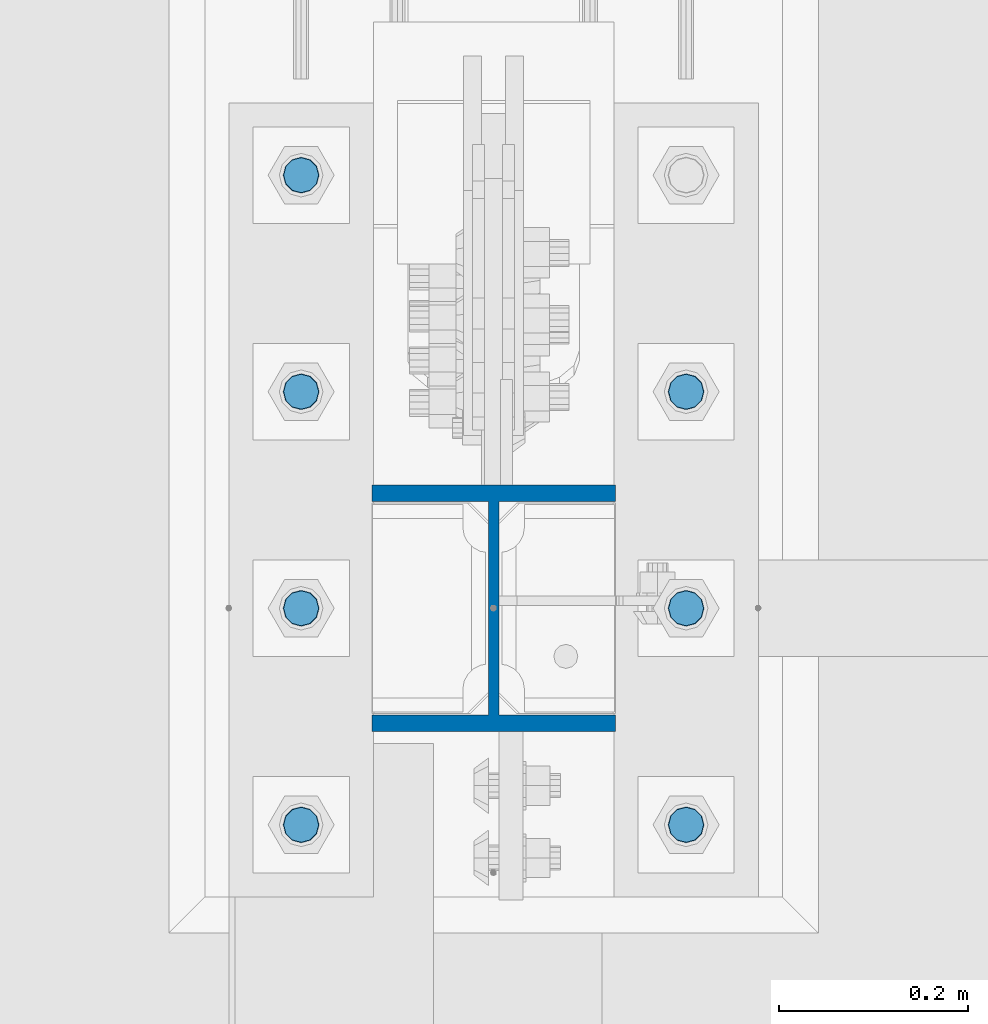
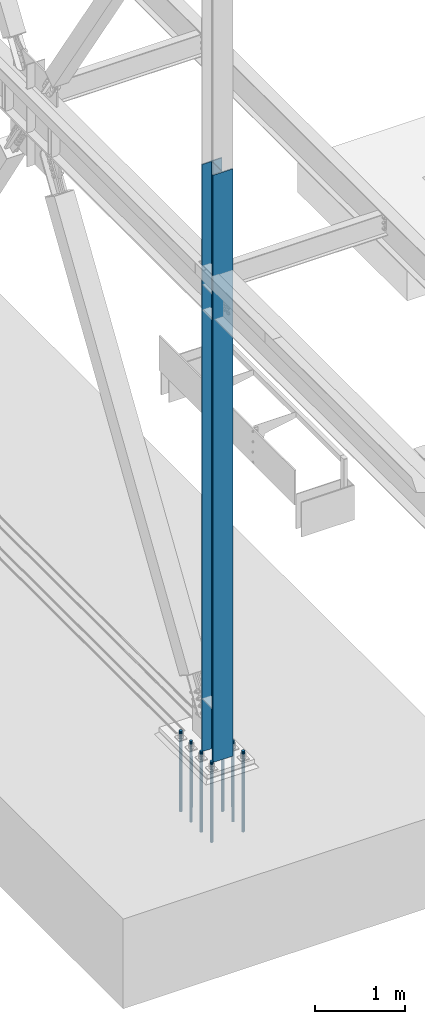
# One storey, part 1346 of 3843: 8 columns, 2 elements without a shape of their own.
"""IFC2X3 building model written with IfcOpenShell, lengths in millimetres."""

from ifc_helpers import new_model, si_unit, frame, origin_with_axes, place, context, subcontext, project, spatial, faceted_brep, material, type_object, element, aggregate, save


model = new_model("IFC2X3")

# Units and contexts
model_context = context("Model", 3, precision=1e-05, world=origin_with_axes())
body_context = subcontext(model_context, "Body", "Model", "MODEL_VIEW")
ifc_project = project(units=[si_unit("LENGTHUNIT", "METRE", prefix="MILLI"), si_unit("AREAUNIT", "SQUARE_METRE"), si_unit("VOLUMEUNIT", "CUBIC_METRE"), si_unit("MASSUNIT", "GRAM", prefix="KILO"), si_unit("TIMEUNIT", "SECOND"), si_unit("PLANEANGLEUNIT", "RADIAN"), si_unit("SOLIDANGLEUNIT", "STERADIAN"), si_unit("THERMODYNAMICTEMPERATUREUNIT", "DEGREE_CELSIUS"), si_unit("LUMINOUSINTENSITYUNIT", "LUMEN")], contexts=[model_context])

# Site, building, storey
site_placement = place(None, origin_with_axes())
site = spatial("IfcSite", under=ifc_project, at=site_placement, CompositionType="ELEMENT")
building_placement = place(site_placement, origin_with_axes())
building = spatial("IfcBuilding", under=site, at=building_placement, Name="Undefined", CompositionType="ELEMENT")
storey_placement = place(building_placement, origin_with_axes())
storey = spatial("IfcBuildingStorey", under=building, at=storey_placement, Name="Undefined", CompositionType="ELEMENT", Elevation=0.0)

# Assembly, column
assembly_1_placement = place(storey_placement, origin_with_axes())
assembly_1 = element("IfcElementAssembly", 1, at=assembly_1_placement, inside=storey, Name="COLUMN", AssemblyPlace="NOTDEFINED", PredefinedType="RIGID_FRAME")
ifc_material_1 = material(Name="STEEL/A992")
column_type_1 = type_object("IfcColumnType", Name="W10X60", PredefinedType="NOTDEFINED")
column_1_placement = place(assembly_1_placement, frame((0.0, 96481.9, 29718.0), z_axis=(0.0, 1.0, 0.0), x_axis=(0.0, 0.0, 1.0)))
column_1 = element("IfcColumn", 2, at=column_1_placement, type_object=column_type_1, material=ifc_material_1, Name="COLUMN", ObjectType="W10X60", context=body_context, shape_type="Brep", body=[
    faceted_brep([(101.599999999999, 128.587499999994, -130.174999999999), (101.599999999999, 128.587499999994, -112.712500000001), (8077.2, 128.5875, -112.712499999994), (8077.2, 128.5875, -130.175000000003), (101.599999999999, 5.55624999999418, -112.712500000001), (8077.2, 5.55625, -112.712499999994), (101.599999999999, 5.55624999999418, 112.712500000001), (8077.2, 5.55625, 112.712499999994), (101.599999999999, 128.587499999994, 112.712500000001), (8077.2, 128.5875, 112.712499999994), (101.599999999999, 128.587499999994, 130.174999999999), (8077.2, 128.5875, 130.175000000003), (101.599999999999, -128.587499999994, 130.174999999999), (8077.2, -128.5875, 130.175000000003), (101.599999999999, -128.587499999994, 112.712500000001), (8077.2, -128.5875, 112.712499999994), (101.599999999999, -5.55624999999418, 112.712500000001), (8077.2, -5.55625, 112.712499999994), (101.599999999999, -5.55624999999418, -112.712500000001), (8077.2, -5.55625, -112.712499999994), (101.599999999999, -128.587499999994, -112.712500000001), (8077.2, -128.5875, -112.712499999994), (101.599999999999, -128.587499999994, -130.174999999999), (8077.2, -128.5875, -130.175000000003)], [[[0, 1, 2, 3]], [[1, 4, 5, 2]], [[4, 6, 7, 5]], [[6, 8, 9, 7]], [[8, 10, 11, 9]], [[10, 12, 13, 11]], [[12, 14, 15, 13]], [[14, 16, 17, 15]], [[16, 18, 19, 17]], [[18, 20, 21, 19]], [[20, 22, 23, 21]], [[22, 0, 3, 23]], [[5, 7, 9, 11, 13, 15, 17, 19, 21, 23, 3, 2]], [[22, 20, 18, 16, 14, 12, 10, 8, 6, 4, 1, 0]]]),
])
aggregate(assembly_1, [column_1])

# Assembly, columns
assembly_2_placement = place(storey_placement, origin_with_axes())
assembly_2 = element("IfcElementAssembly", 3, at=assembly_2_placement, inside=storey, Name="TEMPLATE", AssemblyPlace="NOTDEFINED", PredefinedType="RIGID_FRAME")
ifc_material_2 = material(Name="Undefined/F1554-GR.55")
column_type_2 = type_object("IfcColumnType", PredefinedType="NOTDEFINED")
column_2_placement = place(assembly_2_placement, frame((-203.2, 96253.3, 29718.0), z_axis=(0.0, -1.0, 0.0), x_axis=(0.0, 0.0, -1.0)))
column_2 = element("IfcColumn", 4, at=column_2_placement, type_object=column_type_2, material=ifc_material_2, Name="ANCHOR_ROD", context=body_context, shape_type="Brep", body=[
    faceted_brep([(-209.549999999999, -16.0214699700155, 9.25), (-209.549999999999, -9.25, 16.0214699700118), (-209.549999999999, 0.0, 18.5), (-209.549999999999, 9.25, 16.0214699700118), (-209.549999999999, 16.0214699700155, 9.25), (-209.549999999999, 18.5, 0.0), (-209.549999999999, 16.0214699700155, -9.25), (-209.549999999999, 9.25, -16.0214699700118), (-209.549999999999, 0.0, -18.5), (-209.549999999999, -9.25, -16.0214699700118), (-209.549999999999, -16.0214699700155, -9.25), (-209.549999999999, -18.5, 0.0), (0.0, 18.5, 0.0), (0.0, 16.0214699700118, -9.25), (0.0, 9.25, -16.0214699700155), (0.0, 0.0, -18.5), (0.0, -9.25, -16.0214699700155), (0.0, -16.0214699700118, -9.25), (0.0, -18.5, 0.0), (0.0, -16.0214699700118, 9.25), (0.0, -9.25, 16.0214699700155), (0.0, 0.0, 18.5), (0.0, 9.25, 16.0214699700155), (0.0, 16.0214699700118, 9.25), (0.0, -16.4977839420972, 9.52500000000146), (0.0, -9.52500000000146, 16.4977839420972), (0.0, 0.0, 19.0499989999989), (0.0, 9.52500000000146, 16.4977839420972), (0.0, 16.4977839420972, 9.52500000000146), (0.0, 19.0500000000029, 0.0), (0.0, 16.4977839420972, -9.52500000000146), (0.0, 9.52500000000146, -16.4977839420972), (0.0, 0.0, -19.0499989999989), (0.0, -9.52500000000146, -16.4977839420972), (0.0, -16.4977839420972, -9.52500000000146), (0.0, -19.0500000000029, 0.0), (698.5, -19.0499999999993, 0.0), (698.5, -16.4977839420935, 9.52499999999418), (698.5, -9.52500000000146, 16.4977839420899), (698.5, 0.0, 19.0500000000029), (698.5, 9.52500000000146, 16.4977839420899), (698.5, 16.4977839420935, 9.52499999999418), (698.5, 19.0499999999993, 0.0), (698.5, 16.4977839420935, -9.52499999999418), (698.5, 9.52500000000146, -16.4977839420899), (698.5, 0.0, -19.0500000000029), (698.5, -9.52500000000146, -16.4977839420899), (698.5, -16.4977839420935, -9.52499999999418), (698.5, -9.25, 16.0214699700155), (698.5, 0.0, 18.5), (698.5, 9.25, 16.0214699700155), (698.5, 16.0214699700118, 9.25), (698.5, 18.5, 0.0), (698.5, 16.0214699700118, -9.25), (698.5, 9.25, -16.0214699700155), (698.5, 0.0, -18.5), (698.5, -9.25, -16.0214699700155), (698.5, -16.0214699700118, -9.25), (698.5, -18.5, 0.0), (698.5, -16.0214699700118, 9.25), (889.0, -9.25, -16.0214699700155), (889.0, 0.0, -18.5), (889.0, 9.25, -16.0214699700155), (889.0, 16.0214699700118, -9.25), (889.0, 18.5, 0.0), (889.0, 16.0214699700118, 9.25), (889.0, 9.25, 16.0214699700155), (889.0, 0.0, 18.5), (889.0, -9.25, 16.0214699700155), (889.0, -16.0214699700118, 9.25), (889.0, -18.5, 0.0), (889.0, -16.0214699700118, -9.25)], [[[0, 1, 2, 3, 4, 5, 6, 7, 8, 9, 10, 11]], [[6, 5, 12, 13]], [[7, 6, 13, 14]], [[8, 7, 14, 15]], [[9, 8, 15, 16]], [[10, 9, 16, 17]], [[11, 10, 17, 18]], [[0, 11, 18, 19]], [[1, 0, 19, 20]], [[2, 1, 20, 21]], [[3, 2, 21, 22]], [[4, 3, 22, 23]], [[5, 4, 23, 12]], [[24, 25, 26, 27, 28, 29, 30, 31, 32, 33, 34, 35], [22, 21, 20, 19, 18, 17, 16, 15, 14, 13, 12, 23]], [[24, 35, 36, 37]], [[25, 24, 37, 38]], [[26, 25, 38, 39]], [[27, 26, 39, 40]], [[28, 27, 40, 41]], [[29, 28, 41, 42]], [[30, 29, 42, 43]], [[31, 30, 43, 44]], [[32, 31, 44, 45]], [[33, 32, 45, 46]], [[34, 33, 46, 47]], [[35, 34, 47, 36]], [[46, 45, 44, 43, 42, 41, 40, 39, 38, 37, 36, 47], [48, 49, 50, 51, 52, 53, 54, 55, 56, 57, 58, 59]], [[60, 61, 62, 63, 64, 65, 66, 67, 68, 69, 70, 71]], [[68, 67, 49, 48]], [[69, 68, 48, 59]], [[70, 69, 59, 58]], [[71, 70, 58, 57]], [[60, 71, 57, 56]], [[61, 60, 56, 55]], [[62, 61, 55, 54]], [[63, 62, 54, 53]], [[64, 63, 53, 52]], [[65, 64, 52, 51]], [[66, 65, 51, 50]], [[67, 66, 50, 49]]]),
])
column_3_placement = place(assembly_2_placement, frame((203.2, 96253.3, 29718.0), z_axis=(0.0, 1.0, 0.0), x_axis=(0.0, 0.0, -1.0)))
column_3 = element("IfcColumn", 5, at=column_3_placement, type_object=column_type_2, material=ifc_material_2, Name="ANCHOR_ROD", context=body_context, shape_type="Brep", body=[
    faceted_brep([(-209.549999999999, -16.0214699700155, 9.25), (-209.549999999999, -9.25, 16.0214699700118), (-209.549999999999, 0.0, 18.5), (-209.549999999999, 9.25, 16.0214699700118), (-209.549999999999, 16.0214699700155, 9.25), (-209.549999999999, 18.5, 0.0), (-209.549999999999, 16.0214699700155, -9.25), (-209.549999999999, 9.25, -16.0214699700118), (-209.549999999999, 0.0, -18.5), (-209.549999999999, -9.25, -16.0214699700118), (-209.549999999999, -16.0214699700155, -9.25), (-209.549999999999, -18.5, 0.0), (0.0, 18.5, 0.0), (0.0, 16.0214699700118, -9.25), (0.0, 9.25, -16.0214699700155), (0.0, 0.0, -18.5), (0.0, -9.25, -16.0214699700155), (0.0, -16.0214699700118, -9.25), (0.0, -18.5, 0.0), (0.0, -16.0214699700118, 9.25), (0.0, -9.25, 16.0214699700155), (0.0, 0.0, 18.5), (0.0, 9.25, 16.0214699700155), (0.0, 16.0214699700118, 9.25), (0.0, -16.4977839420972, 9.52500000000146), (0.0, -9.52500000000146, 16.4977839420972), (0.0, 0.0, 19.0499989999989), (0.0, 9.52500000000146, 16.4977839420972), (0.0, 16.4977839420972, 9.52500000000146), (0.0, 19.0500000000029, 0.0), (0.0, 16.4977839420972, -9.52500000000146), (0.0, 9.52500000000146, -16.4977839420972), (0.0, 0.0, -19.0499989999989), (0.0, -9.52500000000146, -16.4977839420972), (0.0, -16.4977839420972, -9.52500000000146), (0.0, -19.0500000000029, 0.0), (698.5, -19.0499999999993, 0.0), (698.5, -16.4977839420935, 9.52499999999418), (698.5, -9.52500000000146, 16.4977839420899), (698.5, 0.0, 19.0500000000029), (698.5, 9.52500000000146, 16.4977839420899), (698.5, 16.4977839420935, 9.52499999999418), (698.5, 19.0499999999993, 0.0), (698.5, 16.4977839420935, -9.52499999999418), (698.5, 9.52500000000146, -16.4977839420899), (698.5, 0.0, -19.0500000000029), (698.5, -9.52500000000146, -16.4977839420899), (698.5, -16.4977839420935, -9.52499999999418), (698.5, -9.25, 16.0214699700155), (698.5, 0.0, 18.5), (698.5, 9.25, 16.0214699700155), (698.5, 16.0214699700118, 9.25), (698.5, 18.5, 0.0), (698.5, 16.0214699700118, -9.25), (698.5, 9.25, -16.0214699700155), (698.5, 0.0, -18.5), (698.5, -9.25, -16.0214699700155), (698.5, -16.0214699700118, -9.25), (698.5, -18.5, 0.0), (698.5, -16.0214699700118, 9.25), (889.0, -9.25, -16.0214699700155), (889.0, 0.0, -18.5), (889.0, 9.25, -16.0214699700155), (889.0, 16.0214699700118, -9.25), (889.0, 18.5, 0.0), (889.0, 16.0214699700118, 9.25), (889.0, 9.25, 16.0214699700155), (889.0, 0.0, 18.5), (889.0, -9.25, 16.0214699700155), (889.0, -16.0214699700118, 9.25), (889.0, -18.5, 0.0), (889.0, -16.0214699700118, -9.25)], [[[0, 1, 2, 3, 4, 5, 6, 7, 8, 9, 10, 11]], [[6, 5, 12, 13]], [[7, 6, 13, 14]], [[8, 7, 14, 15]], [[9, 8, 15, 16]], [[10, 9, 16, 17]], [[11, 10, 17, 18]], [[0, 11, 18, 19]], [[1, 0, 19, 20]], [[2, 1, 20, 21]], [[3, 2, 21, 22]], [[4, 3, 22, 23]], [[5, 4, 23, 12]], [[24, 25, 26, 27, 28, 29, 30, 31, 32, 33, 34, 35], [22, 21, 20, 19, 18, 17, 16, 15, 14, 13, 12, 23]], [[24, 35, 36, 37]], [[25, 24, 37, 38]], [[26, 25, 38, 39]], [[27, 26, 39, 40]], [[28, 27, 40, 41]], [[29, 28, 41, 42]], [[30, 29, 42, 43]], [[31, 30, 43, 44]], [[32, 31, 44, 45]], [[33, 32, 45, 46]], [[34, 33, 46, 47]], [[35, 34, 47, 36]], [[46, 45, 44, 43, 42, 41, 40, 39, 38, 37, 36, 47], [48, 49, 50, 51, 52, 53, 54, 55, 56, 57, 58, 59]], [[60, 61, 62, 63, 64, 65, 66, 67, 68, 69, 70, 71]], [[68, 67, 49, 48]], [[69, 68, 48, 59]], [[70, 69, 59, 58]], [[71, 70, 58, 57]], [[60, 71, 57, 56]], [[61, 60, 56, 55]], [[62, 61, 55, 54]], [[63, 62, 54, 53]], [[64, 63, 53, 52]], [[65, 64, 52, 51]], [[66, 65, 51, 50]], [[67, 66, 50, 49]]]),
])
column_4_placement = place(assembly_2_placement, frame((-203.2, 96481.9, 29718.0), z_axis=(0.0, -1.0, 0.0), x_axis=(0.0, 0.0, -1.0)))
column_4 = element("IfcColumn", 6, at=column_4_placement, type_object=column_type_2, material=ifc_material_2, Name="ANCHOR_ROD", context=body_context, shape_type="Brep", body=[
    faceted_brep([(-209.549999999999, -16.0214699700155, 9.25), (-209.549999999999, -9.25, 16.0214699700118), (-209.549999999999, 0.0, 18.5), (-209.549999999999, 9.25, 16.0214699700118), (-209.549999999999, 16.0214699700155, 9.25), (-209.549999999999, 18.5, 0.0), (-209.549999999999, 16.0214699700155, -9.25), (-209.549999999999, 9.25, -16.0214699700118), (-209.549999999999, 0.0, -18.5), (-209.549999999999, -9.25, -16.0214699700118), (-209.549999999999, -16.0214699700155, -9.25), (-209.549999999999, -18.5, 0.0), (0.0, 18.5, 0.0), (0.0, 16.0214699700118, -9.25), (0.0, 9.25, -16.0214699700155), (0.0, 0.0, -18.5), (0.0, -9.25, -16.0214699700155), (0.0, -16.0214699700118, -9.25), (0.0, -18.5, 0.0), (0.0, -16.0214699700118, 9.25), (0.0, -9.25, 16.0214699700155), (0.0, 0.0, 18.5), (0.0, 9.25, 16.0214699700155), (0.0, 16.0214699700118, 9.25), (0.0, -16.4977839420972, 9.52500000000146), (0.0, -9.52500000000146, 16.4977839420972), (0.0, 0.0, 19.0499989999989), (0.0, 9.52500000000146, 16.4977839420972), (0.0, 16.4977839420972, 9.52500000000146), (0.0, 19.0500000000029, 0.0), (0.0, 16.4977839420972, -9.52500000000146), (0.0, 9.52500000000146, -16.4977839420972), (0.0, 0.0, -19.0499989999989), (0.0, -9.52500000000146, -16.4977839420972), (0.0, -16.4977839420972, -9.52500000000146), (0.0, -19.0500000000029, 0.0), (698.5, -19.0499999999993, 0.0), (698.5, -16.4977839420935, 9.52499999999418), (698.5, -9.52500000000146, 16.4977839420899), (698.5, 0.0, 19.0500000000029), (698.5, 9.52500000000146, 16.4977839420899), (698.5, 16.4977839420935, 9.52499999999418), (698.5, 19.0499999999993, 0.0), (698.5, 16.4977839420935, -9.52499999999418), (698.5, 9.52500000000146, -16.4977839420899), (698.5, 0.0, -19.0500000000029), (698.5, -9.52500000000146, -16.4977839420899), (698.5, -16.4977839420935, -9.52499999999418), (698.5, -9.25, 16.0214699700155), (698.5, 0.0, 18.5), (698.5, 9.25, 16.0214699700155), (698.5, 16.0214699700118, 9.25), (698.5, 18.5, 0.0), (698.5, 16.0214699700118, -9.25), (698.5, 9.25, -16.0214699700155), (698.5, 0.0, -18.5), (698.5, -9.25, -16.0214699700155), (698.5, -16.0214699700118, -9.25), (698.5, -18.5, 0.0), (698.5, -16.0214699700118, 9.25), (889.0, -9.25, -16.0214699700155), (889.0, 0.0, -18.5), (889.0, 9.25, -16.0214699700155), (889.0, 16.0214699700118, -9.25), (889.0, 18.5, 0.0), (889.0, 16.0214699700118, 9.25), (889.0, 9.25, 16.0214699700155), (889.0, 0.0, 18.5), (889.0, -9.25, 16.0214699700155), (889.0, -16.0214699700118, 9.25), (889.0, -18.5, 0.0), (889.0, -16.0214699700118, -9.25)], [[[0, 1, 2, 3, 4, 5, 6, 7, 8, 9, 10, 11]], [[6, 5, 12, 13]], [[7, 6, 13, 14]], [[8, 7, 14, 15]], [[9, 8, 15, 16]], [[10, 9, 16, 17]], [[11, 10, 17, 18]], [[0, 11, 18, 19]], [[1, 0, 19, 20]], [[2, 1, 20, 21]], [[3, 2, 21, 22]], [[4, 3, 22, 23]], [[5, 4, 23, 12]], [[24, 25, 26, 27, 28, 29, 30, 31, 32, 33, 34, 35], [22, 21, 20, 19, 18, 17, 16, 15, 14, 13, 12, 23]], [[24, 35, 36, 37]], [[25, 24, 37, 38]], [[26, 25, 38, 39]], [[27, 26, 39, 40]], [[28, 27, 40, 41]], [[29, 28, 41, 42]], [[30, 29, 42, 43]], [[31, 30, 43, 44]], [[32, 31, 44, 45]], [[33, 32, 45, 46]], [[34, 33, 46, 47]], [[35, 34, 47, 36]], [[46, 45, 44, 43, 42, 41, 40, 39, 38, 37, 36, 47], [48, 49, 50, 51, 52, 53, 54, 55, 56, 57, 58, 59]], [[60, 61, 62, 63, 64, 65, 66, 67, 68, 69, 70, 71]], [[68, 67, 49, 48]], [[69, 68, 48, 59]], [[70, 69, 59, 58]], [[71, 70, 58, 57]], [[60, 71, 57, 56]], [[61, 60, 56, 55]], [[62, 61, 55, 54]], [[63, 62, 54, 53]], [[64, 63, 53, 52]], [[65, 64, 52, 51]], [[66, 65, 51, 50]], [[67, 66, 50, 49]]]),
])
column_5_placement = place(assembly_2_placement, frame((203.2, 96481.9, 29718.0), z_axis=(0.0, 1.0, 0.0), x_axis=(0.0, 0.0, -1.0)))
column_5 = element("IfcColumn", 7, at=column_5_placement, type_object=column_type_2, material=ifc_material_2, Name="ANCHOR_ROD", context=body_context, shape_type="Brep", body=[
    faceted_brep([(-209.549999999999, -16.0214699700155, 9.25), (-209.549999999999, -9.25, 16.0214699700118), (-209.549999999999, 0.0, 18.5), (-209.549999999999, 9.25, 16.0214699700118), (-209.549999999999, 16.0214699700155, 9.25), (-209.549999999999, 18.5, 0.0), (-209.549999999999, 16.0214699700155, -9.25), (-209.549999999999, 9.25, -16.0214699700118), (-209.549999999999, 0.0, -18.5), (-209.549999999999, -9.25, -16.0214699700118), (-209.549999999999, -16.0214699700155, -9.25), (-209.549999999999, -18.5, 0.0), (0.0, 18.5, 0.0), (0.0, 16.0214699700118, -9.25), (0.0, 9.25, -16.0214699700155), (0.0, 0.0, -18.5), (0.0, -9.25, -16.0214699700155), (0.0, -16.0214699700118, -9.25), (0.0, -18.5, 0.0), (0.0, -16.0214699700118, 9.25), (0.0, -9.25, 16.0214699700155), (0.0, 0.0, 18.5), (0.0, 9.25, 16.0214699700155), (0.0, 16.0214699700118, 9.25), (0.0, -16.4977839420972, 9.52500000000146), (0.0, -9.52500000000146, 16.4977839420972), (0.0, 0.0, 19.0499989999989), (0.0, 9.52500000000146, 16.4977839420972), (0.0, 16.4977839420972, 9.52500000000146), (0.0, 19.0500000000029, 0.0), (0.0, 16.4977839420972, -9.52500000000146), (0.0, 9.52500000000146, -16.4977839420972), (0.0, 0.0, -19.0499989999989), (0.0, -9.52500000000146, -16.4977839420972), (0.0, -16.4977839420972, -9.52500000000146), (0.0, -19.0500000000029, 0.0), (698.5, -19.0499999999993, 0.0), (698.5, -16.4977839420935, 9.52499999999418), (698.5, -9.52500000000146, 16.4977839420899), (698.5, 0.0, 19.0500000000029), (698.5, 9.52500000000146, 16.4977839420899), (698.5, 16.4977839420935, 9.52499999999418), (698.5, 19.0499999999993, 0.0), (698.5, 16.4977839420935, -9.52499999999418), (698.5, 9.52500000000146, -16.4977839420899), (698.5, 0.0, -19.0500000000029), (698.5, -9.52500000000146, -16.4977839420899), (698.5, -16.4977839420935, -9.52499999999418), (698.5, -9.25, 16.0214699700155), (698.5, 0.0, 18.5), (698.5, 9.25, 16.0214699700155), (698.5, 16.0214699700118, 9.25), (698.5, 18.5, 0.0), (698.5, 16.0214699700118, -9.25), (698.5, 9.25, -16.0214699700155), (698.5, 0.0, -18.5), (698.5, -9.25, -16.0214699700155), (698.5, -16.0214699700118, -9.25), (698.5, -18.5, 0.0), (698.5, -16.0214699700118, 9.25), (889.0, -9.25, -16.0214699700155), (889.0, 0.0, -18.5), (889.0, 9.25, -16.0214699700155), (889.0, 16.0214699700118, -9.25), (889.0, 18.5, 0.0), (889.0, 16.0214699700118, 9.25), (889.0, 9.25, 16.0214699700155), (889.0, 0.0, 18.5), (889.0, -9.25, 16.0214699700155), (889.0, -16.0214699700118, 9.25), (889.0, -18.5, 0.0), (889.0, -16.0214699700118, -9.25)], [[[0, 1, 2, 3, 4, 5, 6, 7, 8, 9, 10, 11]], [[6, 5, 12, 13]], [[7, 6, 13, 14]], [[8, 7, 14, 15]], [[9, 8, 15, 16]], [[10, 9, 16, 17]], [[11, 10, 17, 18]], [[0, 11, 18, 19]], [[1, 0, 19, 20]], [[2, 1, 20, 21]], [[3, 2, 21, 22]], [[4, 3, 22, 23]], [[5, 4, 23, 12]], [[24, 25, 26, 27, 28, 29, 30, 31, 32, 33, 34, 35], [22, 21, 20, 19, 18, 17, 16, 15, 14, 13, 12, 23]], [[24, 35, 36, 37]], [[25, 24, 37, 38]], [[26, 25, 38, 39]], [[27, 26, 39, 40]], [[28, 27, 40, 41]], [[29, 28, 41, 42]], [[30, 29, 42, 43]], [[31, 30, 43, 44]], [[32, 31, 44, 45]], [[33, 32, 45, 46]], [[34, 33, 46, 47]], [[35, 34, 47, 36]], [[46, 45, 44, 43, 42, 41, 40, 39, 38, 37, 36, 47], [48, 49, 50, 51, 52, 53, 54, 55, 56, 57, 58, 59]], [[60, 61, 62, 63, 64, 65, 66, 67, 68, 69, 70, 71]], [[68, 67, 49, 48]], [[69, 68, 48, 59]], [[70, 69, 59, 58]], [[71, 70, 58, 57]], [[60, 71, 57, 56]], [[61, 60, 56, 55]], [[62, 61, 55, 54]], [[63, 62, 54, 53]], [[64, 63, 53, 52]], [[65, 64, 52, 51]], [[66, 65, 51, 50]], [[67, 66, 50, 49]]]),
])
column_6_placement = place(assembly_2_placement, frame((-203.2, 96710.5, 29718.0), z_axis=(0.0, -1.0, 0.0), x_axis=(0.0, 0.0, -1.0)))
column_6 = element("IfcColumn", 8, at=column_6_placement, type_object=column_type_2, material=ifc_material_2, Name="ANCHOR_ROD", context=body_context, shape_type="Brep", body=[
    faceted_brep([(-209.549999999999, -16.0214699700155, 9.25), (-209.549999999999, -9.25, 16.0214699700118), (-209.549999999999, 0.0, 18.5), (-209.549999999999, 9.25, 16.0214699700118), (-209.549999999999, 16.0214699700155, 9.25), (-209.549999999999, 18.5, 0.0), (-209.549999999999, 16.0214699700155, -9.25), (-209.549999999999, 9.25, -16.0214699700118), (-209.549999999999, 0.0, -18.5), (-209.549999999999, -9.25, -16.0214699700118), (-209.549999999999, -16.0214699700155, -9.25), (-209.549999999999, -18.5, 0.0), (0.0, 18.5, 0.0), (0.0, 16.0214699700118, -9.25), (0.0, 9.25, -16.0214699700155), (0.0, 0.0, -18.5), (0.0, -9.25, -16.0214699700155), (0.0, -16.0214699700118, -9.25), (0.0, -18.5, 0.0), (0.0, -16.0214699700118, 9.25), (0.0, -9.25, 16.0214699700155), (0.0, 0.0, 18.5), (0.0, 9.25, 16.0214699700155), (0.0, 16.0214699700118, 9.25), (0.0, -16.4977839420972, 9.52500000000146), (0.0, -9.52500000000146, 16.4977839420972), (0.0, 0.0, 19.0499989999989), (0.0, 9.52500000000146, 16.4977839420972), (0.0, 16.4977839420972, 9.52500000000146), (0.0, 19.0500000000029, 0.0), (0.0, 16.4977839420972, -9.52500000000146), (0.0, 9.52500000000146, -16.4977839420972), (0.0, 0.0, -19.0499989999989), (0.0, -9.52500000000146, -16.4977839420972), (0.0, -16.4977839420972, -9.52500000000146), (0.0, -19.0500000000029, 0.0), (698.5, -19.0499999999993, 0.0), (698.5, -16.4977839420935, 9.52499999999418), (698.5, -9.52500000000146, 16.4977839420899), (698.5, 0.0, 19.0500000000029), (698.5, 9.52500000000146, 16.4977839420899), (698.5, 16.4977839420935, 9.52499999999418), (698.5, 19.0499999999993, 0.0), (698.5, 16.4977839420935, -9.52499999999418), (698.5, 9.52500000000146, -16.4977839420899), (698.5, 0.0, -19.0500000000029), (698.5, -9.52500000000146, -16.4977839420899), (698.5, -16.4977839420935, -9.52499999999418), (698.5, -9.25, 16.0214699700155), (698.5, 0.0, 18.5), (698.5, 9.25, 16.0214699700155), (698.5, 16.0214699700118, 9.25), (698.5, 18.5, 0.0), (698.5, 16.0214699700118, -9.25), (698.5, 9.25, -16.0214699700155), (698.5, 0.0, -18.5), (698.5, -9.25, -16.0214699700155), (698.5, -16.0214699700118, -9.25), (698.5, -18.5, 0.0), (698.5, -16.0214699700118, 9.25), (889.0, -9.25, -16.0214699700155), (889.0, 0.0, -18.5), (889.0, 9.25, -16.0214699700155), (889.0, 16.0214699700118, -9.25), (889.0, 18.5, 0.0), (889.0, 16.0214699700118, 9.25), (889.0, 9.25, 16.0214699700155), (889.0, 0.0, 18.5), (889.0, -9.25, 16.0214699700155), (889.0, -16.0214699700118, 9.25), (889.0, -18.5, 0.0), (889.0, -16.0214699700118, -9.25)], [[[0, 1, 2, 3, 4, 5, 6, 7, 8, 9, 10, 11]], [[6, 5, 12, 13]], [[7, 6, 13, 14]], [[8, 7, 14, 15]], [[9, 8, 15, 16]], [[10, 9, 16, 17]], [[11, 10, 17, 18]], [[0, 11, 18, 19]], [[1, 0, 19, 20]], [[2, 1, 20, 21]], [[3, 2, 21, 22]], [[4, 3, 22, 23]], [[5, 4, 23, 12]], [[24, 25, 26, 27, 28, 29, 30, 31, 32, 33, 34, 35], [22, 21, 20, 19, 18, 17, 16, 15, 14, 13, 12, 23]], [[24, 35, 36, 37]], [[25, 24, 37, 38]], [[26, 25, 38, 39]], [[27, 26, 39, 40]], [[28, 27, 40, 41]], [[29, 28, 41, 42]], [[30, 29, 42, 43]], [[31, 30, 43, 44]], [[32, 31, 44, 45]], [[33, 32, 45, 46]], [[34, 33, 46, 47]], [[35, 34, 47, 36]], [[46, 45, 44, 43, 42, 41, 40, 39, 38, 37, 36, 47], [48, 49, 50, 51, 52, 53, 54, 55, 56, 57, 58, 59]], [[60, 61, 62, 63, 64, 65, 66, 67, 68, 69, 70, 71]], [[68, 67, 49, 48]], [[69, 68, 48, 59]], [[70, 69, 59, 58]], [[71, 70, 58, 57]], [[60, 71, 57, 56]], [[61, 60, 56, 55]], [[62, 61, 55, 54]], [[63, 62, 54, 53]], [[64, 63, 53, 52]], [[65, 64, 52, 51]], [[66, 65, 51, 50]], [[67, 66, 50, 49]]]),
])
column_7_placement = place(assembly_2_placement, frame((203.2, 96710.5, 29718.0), z_axis=(0.0, 1.0, 0.0), x_axis=(0.0, 0.0, -1.0)))
column_7 = element("IfcColumn", 9, at=column_7_placement, type_object=column_type_2, material=ifc_material_2, Name="ANCHOR_ROD", context=body_context, shape_type="Brep", body=[
    faceted_brep([(-209.549999999999, -16.0214699700155, 9.25), (-209.549999999999, -9.25, 16.0214699700118), (-209.549999999999, 0.0, 18.5), (-209.549999999999, 9.25, 16.0214699700118), (-209.549999999999, 16.0214699700155, 9.25), (-209.549999999999, 18.5, 0.0), (-209.549999999999, 16.0214699700155, -9.25), (-209.549999999999, 9.25, -16.0214699700118), (-209.549999999999, 0.0, -18.5), (-209.549999999999, -9.25, -16.0214699700118), (-209.549999999999, -16.0214699700155, -9.25), (-209.549999999999, -18.5, 0.0), (0.0, 18.5, 0.0), (0.0, 16.0214699700118, -9.25), (0.0, 9.25, -16.0214699700155), (0.0, 0.0, -18.5), (0.0, -9.25, -16.0214699700155), (0.0, -16.0214699700118, -9.25), (0.0, -18.5, 0.0), (0.0, -16.0214699700118, 9.25), (0.0, -9.25, 16.0214699700155), (0.0, 0.0, 18.5), (0.0, 9.25, 16.0214699700155), (0.0, 16.0214699700118, 9.25), (0.0, -16.4977839420972, 9.52500000000146), (0.0, -9.52500000000146, 16.4977839420972), (0.0, 0.0, 19.0499989999989), (0.0, 9.52500000000146, 16.4977839420972), (0.0, 16.4977839420972, 9.52500000000146), (0.0, 19.0500000000029, 0.0), (0.0, 16.4977839420972, -9.52500000000146), (0.0, 9.52500000000146, -16.4977839420972), (0.0, 0.0, -19.0499989999989), (0.0, -9.52500000000146, -16.4977839420972), (0.0, -16.4977839420972, -9.52500000000146), (0.0, -19.0500000000029, 0.0), (698.5, -19.0499999999993, 0.0), (698.5, -16.4977839420935, 9.52499999999418), (698.5, -9.52500000000146, 16.4977839420899), (698.5, 0.0, 19.0500000000029), (698.5, 9.52500000000146, 16.4977839420899), (698.5, 16.4977839420935, 9.52499999999418), (698.5, 19.0499999999993, 0.0), (698.5, 16.4977839420935, -9.52499999999418), (698.5, 9.52500000000146, -16.4977839420899), (698.5, 0.0, -19.0500000000029), (698.5, -9.52500000000146, -16.4977839420899), (698.5, -16.4977839420935, -9.52499999999418), (698.5, -9.25, 16.0214699700155), (698.5, 0.0, 18.5), (698.5, 9.25, 16.0214699700155), (698.5, 16.0214699700118, 9.25), (698.5, 18.5, 0.0), (698.5, 16.0214699700118, -9.25), (698.5, 9.25, -16.0214699700155), (698.5, 0.0, -18.5), (698.5, -9.25, -16.0214699700155), (698.5, -16.0214699700118, -9.25), (698.5, -18.5, 0.0), (698.5, -16.0214699700118, 9.25), (889.0, -9.25, -16.0214699700155), (889.0, 0.0, -18.5), (889.0, 9.25, -16.0214699700155), (889.0, 16.0214699700118, -9.25), (889.0, 18.5, 0.0), (889.0, 16.0214699700118, 9.25), (889.0, 9.25, 16.0214699700155), (889.0, 0.0, 18.5), (889.0, -9.25, 16.0214699700155), (889.0, -16.0214699700118, 9.25), (889.0, -18.5, 0.0), (889.0, -16.0214699700118, -9.25)], [[[0, 1, 2, 3, 4, 5, 6, 7, 8, 9, 10, 11]], [[6, 5, 12, 13]], [[7, 6, 13, 14]], [[8, 7, 14, 15]], [[9, 8, 15, 16]], [[10, 9, 16, 17]], [[11, 10, 17, 18]], [[0, 11, 18, 19]], [[1, 0, 19, 20]], [[2, 1, 20, 21]], [[3, 2, 21, 22]], [[4, 3, 22, 23]], [[5, 4, 23, 12]], [[24, 25, 26, 27, 28, 29, 30, 31, 32, 33, 34, 35], [22, 21, 20, 19, 18, 17, 16, 15, 14, 13, 12, 23]], [[24, 35, 36, 37]], [[25, 24, 37, 38]], [[26, 25, 38, 39]], [[27, 26, 39, 40]], [[28, 27, 40, 41]], [[29, 28, 41, 42]], [[30, 29, 42, 43]], [[31, 30, 43, 44]], [[32, 31, 44, 45]], [[33, 32, 45, 46]], [[34, 33, 46, 47]], [[35, 34, 47, 36]], [[46, 45, 44, 43, 42, 41, 40, 39, 38, 37, 36, 47], [48, 49, 50, 51, 52, 53, 54, 55, 56, 57, 58, 59]], [[60, 61, 62, 63, 64, 65, 66, 67, 68, 69, 70, 71]], [[68, 67, 49, 48]], [[69, 68, 48, 59]], [[70, 69, 59, 58]], [[71, 70, 58, 57]], [[60, 71, 57, 56]], [[61, 60, 56, 55]], [[62, 61, 55, 54]], [[63, 62, 54, 53]], [[64, 63, 53, 52]], [[65, 64, 52, 51]], [[66, 65, 51, 50]], [[67, 66, 50, 49]]]),
])
column_8_placement = place(assembly_2_placement, frame((-203.2, 96939.1, 29718.0), z_axis=(0.0, -1.0, 0.0), x_axis=(0.0, 0.0, -1.0)))
column_8 = element("IfcColumn", 10, at=column_8_placement, type_object=column_type_2, material=ifc_material_2, Name="ANCHOR_ROD", context=body_context, shape_type="Brep", body=[
    faceted_brep([(-209.549999999999, -16.0214699700155, 9.25), (-209.549999999999, -9.25, 16.0214699700118), (-209.549999999999, 0.0, 18.5), (-209.549999999999, 9.25, 16.0214699700118), (-209.549999999999, 16.0214699700155, 9.25), (-209.549999999999, 18.5, 0.0), (-209.549999999999, 16.0214699700155, -9.25), (-209.549999999999, 9.25, -16.0214699700118), (-209.549999999999, 0.0, -18.5), (-209.549999999999, -9.25, -16.0214699700118), (-209.549999999999, -16.0214699700155, -9.25), (-209.549999999999, -18.5, 0.0), (0.0, 18.5, 0.0), (0.0, 16.0214699700118, -9.25), (0.0, 9.25, -16.0214699700155), (0.0, 0.0, -18.5), (0.0, -9.25, -16.0214699700155), (0.0, -16.0214699700118, -9.25), (0.0, -18.5, 0.0), (0.0, -16.0214699700118, 9.25), (0.0, -9.25, 16.0214699700155), (0.0, 0.0, 18.5), (0.0, 9.25, 16.0214699700155), (0.0, 16.0214699700118, 9.25), (0.0, -16.4977839420972, 9.52500000000146), (0.0, -9.52500000000146, 16.4977839420972), (0.0, 0.0, 19.0499989999989), (0.0, 9.52500000000146, 16.4977839420972), (0.0, 16.4977839420972, 9.52500000000146), (0.0, 19.0500000000029, 0.0), (0.0, 16.4977839420972, -9.52500000000146), (0.0, 9.52500000000146, -16.4977839420972), (0.0, 0.0, -19.0499989999989), (0.0, -9.52500000000146, -16.4977839420972), (0.0, -16.4977839420972, -9.52500000000146), (0.0, -19.0500000000029, 0.0), (698.5, -19.0499999999993, 0.0), (698.5, -16.4977839420935, 9.52499999999418), (698.5, -9.52500000000146, 16.4977839420899), (698.5, 0.0, 19.0500000000029), (698.5, 9.52500000000146, 16.4977839420899), (698.5, 16.4977839420935, 9.52499999999418), (698.5, 19.0499999999993, 0.0), (698.5, 16.4977839420935, -9.52499999999418), (698.5, 9.52500000000146, -16.4977839420899), (698.5, 0.0, -19.0500000000029), (698.5, -9.52500000000146, -16.4977839420899), (698.5, -16.4977839420935, -9.52499999999418), (698.5, -9.25, 16.0214699700155), (698.5, 0.0, 18.5), (698.5, 9.25, 16.0214699700155), (698.5, 16.0214699700118, 9.25), (698.5, 18.5, 0.0), (698.5, 16.0214699700118, -9.25), (698.5, 9.25, -16.0214699700155), (698.5, 0.0, -18.5), (698.5, -9.25, -16.0214699700155), (698.5, -16.0214699700118, -9.25), (698.5, -18.5, 0.0), (698.5, -16.0214699700118, 9.25), (889.0, -9.25, -16.0214699700155), (889.0, 0.0, -18.5), (889.0, 9.25, -16.0214699700155), (889.0, 16.0214699700118, -9.25), (889.0, 18.5, 0.0), (889.0, 16.0214699700118, 9.25), (889.0, 9.25, 16.0214699700155), (889.0, 0.0, 18.5), (889.0, -9.25, 16.0214699700155), (889.0, -16.0214699700118, 9.25), (889.0, -18.5, 0.0), (889.0, -16.0214699700118, -9.25)], [[[0, 1, 2, 3, 4, 5, 6, 7, 8, 9, 10, 11]], [[6, 5, 12, 13]], [[7, 6, 13, 14]], [[8, 7, 14, 15]], [[9, 8, 15, 16]], [[10, 9, 16, 17]], [[11, 10, 17, 18]], [[0, 11, 18, 19]], [[1, 0, 19, 20]], [[2, 1, 20, 21]], [[3, 2, 21, 22]], [[4, 3, 22, 23]], [[5, 4, 23, 12]], [[24, 25, 26, 27, 28, 29, 30, 31, 32, 33, 34, 35], [22, 21, 20, 19, 18, 17, 16, 15, 14, 13, 12, 23]], [[24, 35, 36, 37]], [[25, 24, 37, 38]], [[26, 25, 38, 39]], [[27, 26, 39, 40]], [[28, 27, 40, 41]], [[29, 28, 41, 42]], [[30, 29, 42, 43]], [[31, 30, 43, 44]], [[32, 31, 44, 45]], [[33, 32, 45, 46]], [[34, 33, 46, 47]], [[35, 34, 47, 36]], [[46, 45, 44, 43, 42, 41, 40, 39, 38, 37, 36, 47], [48, 49, 50, 51, 52, 53, 54, 55, 56, 57, 58, 59]], [[60, 61, 62, 63, 64, 65, 66, 67, 68, 69, 70, 71]], [[68, 67, 49, 48]], [[69, 68, 48, 59]], [[70, 69, 59, 58]], [[71, 70, 58, 57]], [[60, 71, 57, 56]], [[61, 60, 56, 55]], [[62, 61, 55, 54]], [[63, 62, 54, 53]], [[64, 63, 53, 52]], [[65, 64, 52, 51]], [[66, 65, 51, 50]], [[67, 66, 50, 49]]]),
])
aggregate(assembly_2, [column_2, column_3, column_4, column_5, column_6, column_7, column_8])

save(model, "model.ifc")
